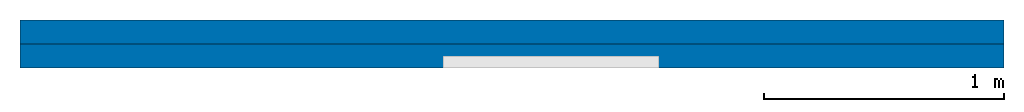
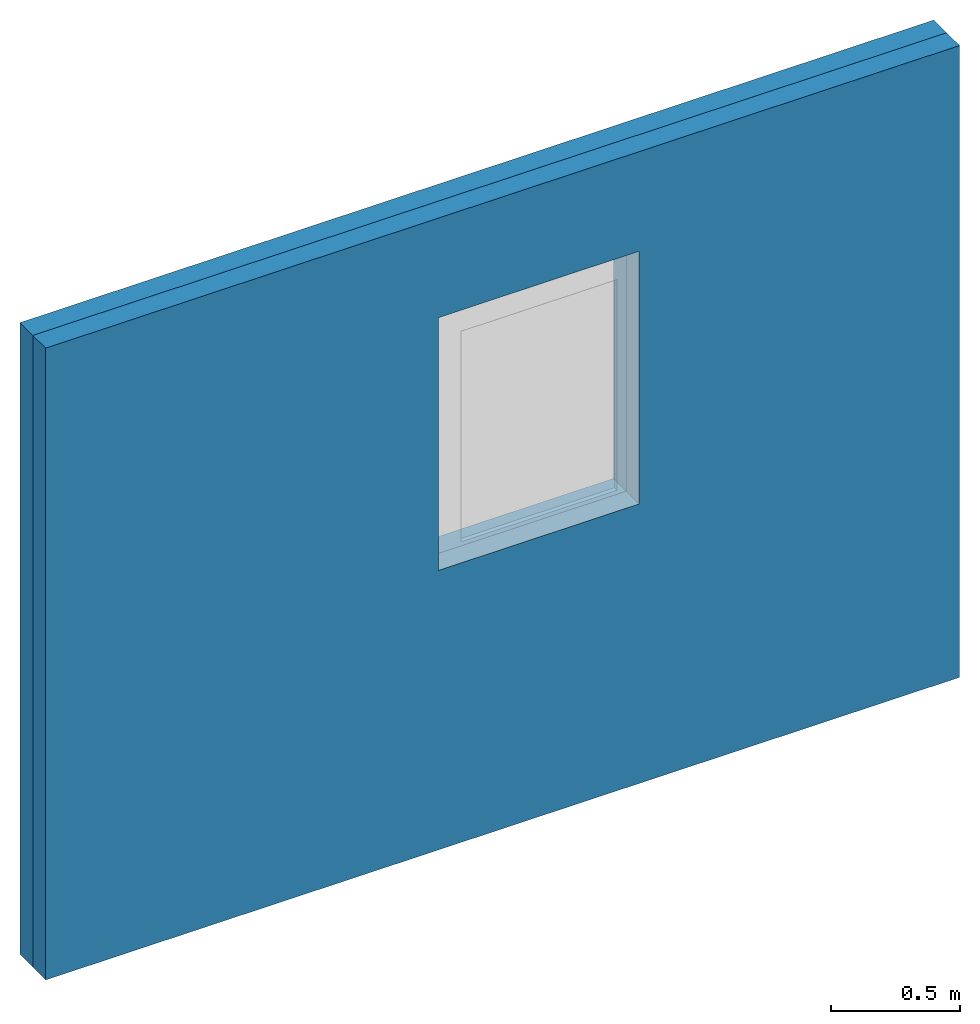
# One storey, part 1 of 2: 2 walls, 1 opening, 1 element without a shape of its own.
"""IFC4 building model written with IfcOpenShell, lengths in millimetres."""

from ifc_helpers import new_model, entity, si_unit, converted_unit, frame, origin_with_axes, origin_2d_with_axis, place, context, subcontext, project, spatial, line, indexed_curve, outline, extrude, source, transform, mapped, material, layer, layer_set, layer_usage, type_object, element, aggregate, save


model = new_model("IFC4")

# Units and contexts
model_context = context("Model", 3, precision=1e-05, world=origin_with_axes())
plan_context = context("Plan", 2, precision=1e-05, world=origin_2d_with_axis())
body_context = subcontext(model_context, "Body", "Model", "MODEL_VIEW")
ifc_project = project(units=[si_unit("VOLUMEUNIT", "CUBIC_METRE"), si_unit("LENGTHUNIT", "METRE", prefix="MILLI"), converted_unit("PLANEANGLEUNIT", "degree", entity("IfcReal", 0.0174532925199433), si_unit("PLANEANGLEUNIT", "RADIAN"), dimensions=[0, 0, 0, 0, 0, 0, 0]), si_unit("AREAUNIT", "SQUARE_METRE")], contexts=[model_context, plan_context])

# Site, building, storey
site_placement = place(None, origin_with_axes())
site = spatial("IfcSite", under=ifc_project, at=site_placement)
building_placement = place(site_placement, origin_with_axes())
building = spatial("IfcBuilding", under=site, at=building_placement, Name="Building")
storey_placement = place(building_placement, origin_with_axes())
storey = spatial("IfcBuildingStorey", under=building, at=storey_placement, Name="Storey")

# Walls, opening
wall_1_placement = place(storey_placement, frame((4104.25806045532, 1651.69334411621, -1194.52667236328), z_axis=(0.0, 0.0, 1.0), x_axis=(1.0, 0.0, 0.0)))
wall_1 = element("IfcWall", 1, at=wall_1_placement, inside=storey, Name="Assembly")
shared_shape = source(origin_with_axes(), body_context, "Body", "SweptSolid", [
    extrude(outline(indexed_curve([(0.0, 0.0), (899.999938964844, 0.0), (899.999938964844, 1200.0), (0.0, 1200.0)], segments=[line(1, 2, 3, 4, 1)])), frame((0.0, -600.0, 0.0), z_axis=(0.0, -1.0, 0.0), x_axis=(1.0, 0.0, 0.0)), (0.0, 0.0, -1.0), 1200.0),
])
opening_placement = place(wall_1_placement, frame((-2339.15567398071, -1651.78442001343, 2521.75188064575), z_axis=(0.0, 0.0, 1.0), x_axis=(1.0, 0.0, 0.0)))
element("IfcOpeningElement", 2, at=opening_placement, cuts=wall_1, PredefinedType="OPENING", context=body_context, shape_type="MappedRepresentation", body=[
    mapped(shared_shape, transform((0.0, 0.0, 0.0), x_axis=(1.0, 0.0, 0.0), y_axis=(0.0, 1.0, 0.0), z_axis=(0.0, 0.0, 1.0), scale=1.0)),
])
ifc_material = material()
ifc_layer = layer(ifc_material, 100.0)
ifc_layer_set = layer_set([ifc_layer])
ifc_layer_usage_1 = layer_usage(ifc_layer_set, "AXIS2", "POSITIVE", 0.0)
wall_type = type_object("IfcWallType", Name="WAL100", PredefinedType="NOTDEFINED", material=ifc_layer_set)
wall_2_placement = place(wall_1_placement, frame((-4104.25806045532, -1651.6908652136, 1194.52667236328), z_axis=(0.0, 0.0, 1.0), x_axis=(0.999999999999545, -9.53674316405816e-07, 0.0)))
wall_2 = element("IfcWall", 3, at=wall_2_placement, type_object=wall_type, material=ifc_layer_usage_1, Name="Wall", context=body_context, shape_type="SweptSolid", body=[
    extrude(outline(indexed_curve([(0.0, 0.0), (0.0, 100.0), (4104.25808929169, 100.0), (4104.25808929169, 0.0), (0.0, 0.0)], self_intersect=False)), origin_with_axes(), (0.0, 0.0, 1.0), 3000.0),
])
ifc_layer_usage_2 = layer_usage(ifc_layer_set, "AXIS2", "POSITIVE", 0.0)
wall_3_placement = place(wall_1_placement, frame((-4104.25796508789, -1551.69081687927, 1194.52667236328), z_axis=(0.0, 0.0, 1.0), x_axis=(0.999999999999545, -9.53674316405816e-07, 0.0)))
wall_3 = element("IfcWall", 4, at=wall_3_placement, type_object=wall_type, material=ifc_layer_usage_2, Name="Wall", context=body_context, shape_type="SweptSolid", body=[
    extrude(outline(indexed_curve([(0.0, 0.0), (0.0, 100.0), (4104.25808929169, 100.0), (4104.25808929169, 0.0), (0.0, 0.0)], self_intersect=False)), origin_with_axes(), (0.0, 0.0, 1.0), 3000.0),
])
aggregate(wall_1, [wall_2, wall_3])

save(model, "model.ifc")
